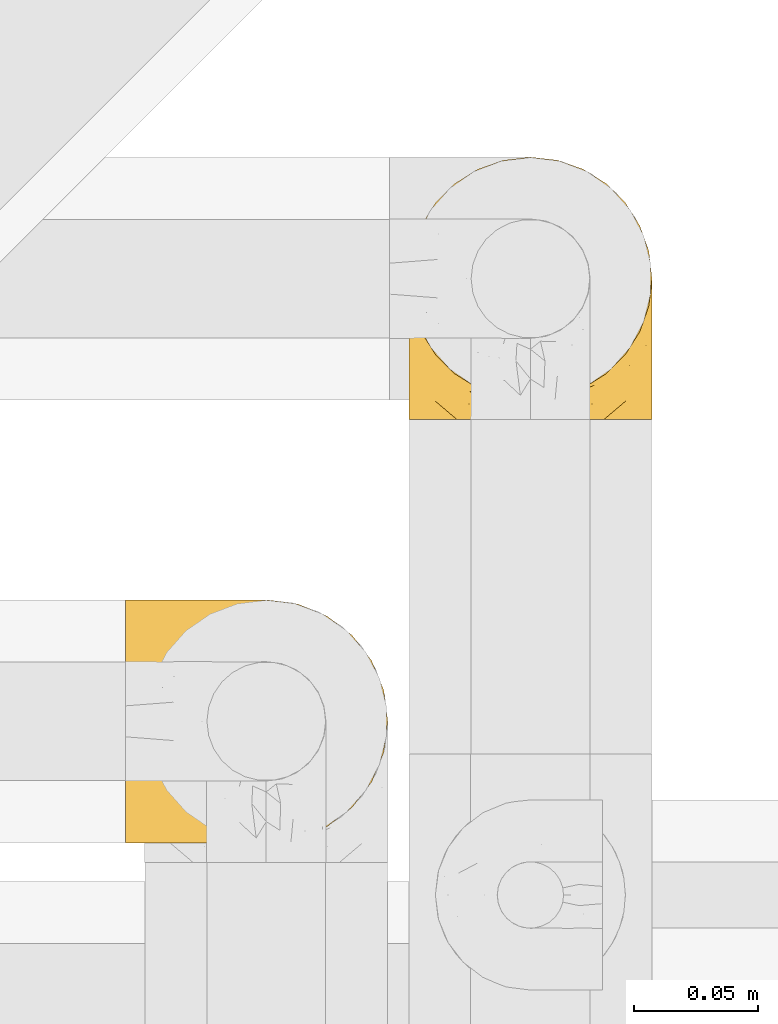
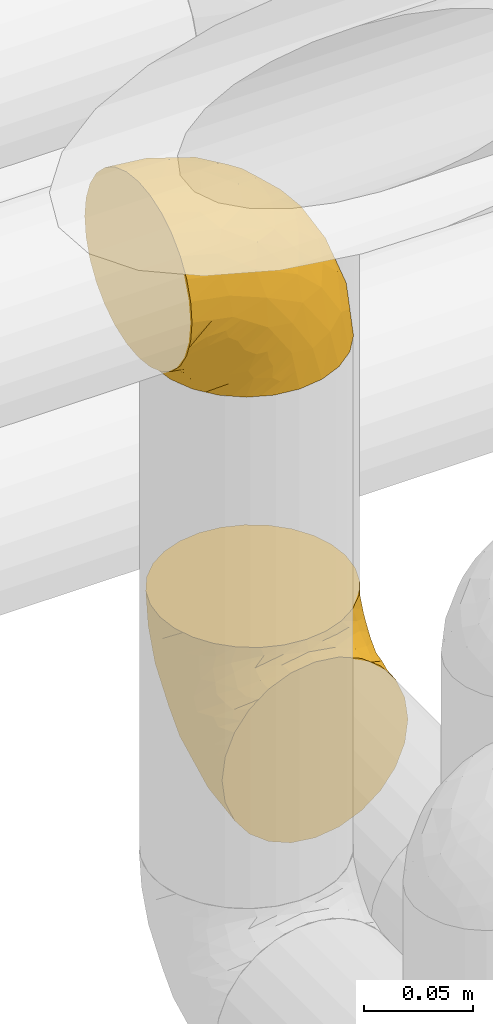
# One storey, part 372 of 827: 2 coverings.
"""IFC2X3 building model written with IfcOpenShell, lengths in millimetres."""

from ifc_helpers import new_model, entity, si_unit, converted_unit, derived_unit, direction, frame, origin, place, context, subcontext, project, spatial, faceted_brep, element, save


model = new_model("IFC2X3")

# Units and contexts
model_context = context("Model", 3, precision=0.01, world=origin(), true_north=direction((6.12303176911189e-17, 1.0)))
body_context = subcontext(model_context, "Body", "Model", "MODEL_VIEW")
ifc_project = project(units=[si_unit("LENGTHUNIT", "METRE", prefix="MILLI"), si_unit("AREAUNIT", "SQUARE_METRE"), si_unit("VOLUMEUNIT", "CUBIC_METRE"), converted_unit("PLANEANGLEUNIT", "DEGREE", entity("IfcRatioMeasure", 0.0174532925199433), si_unit("PLANEANGLEUNIT", "RADIAN"), dimensions=[0, 0, 0, 0, 0, 0, 0]), si_unit("MASSUNIT", "GRAM", prefix="KILO"), derived_unit("MASSDENSITYUNIT", [(si_unit("MASSUNIT", "GRAM", prefix="KILO"), 1), (si_unit("LENGTHUNIT", "METRE"), -3)]), derived_unit("MOMENTOFINERTIAUNIT", [(si_unit("LENGTHUNIT", "METRE"), 4)]), si_unit("TIMEUNIT", "SECOND"), si_unit("FREQUENCYUNIT", "HERTZ"), si_unit("THERMODYNAMICTEMPERATUREUNIT", "DEGREE_CELSIUS"), derived_unit("THERMALTRANSMITTANCEUNIT", [(si_unit("MASSUNIT", "GRAM", prefix="KILO"), 1), (si_unit("THERMODYNAMICTEMPERATUREUNIT", "KELVIN"), -1), (si_unit("TIMEUNIT", "SECOND"), -3)]), derived_unit("VOLUMETRICFLOWRATEUNIT", [(si_unit("LENGTHUNIT", "METRE"), 3), (si_unit("TIMEUNIT", "SECOND"), -1)]), derived_unit("MASSFLOWRATEUNIT", [(si_unit("MASSUNIT", "GRAM", prefix="KILO"), 1), (si_unit("TIMEUNIT", "SECOND"), -1)]), derived_unit("ROTATIONALFREQUENCYUNIT", [(si_unit("TIMEUNIT", "SECOND"), -1)]), si_unit("ELECTRICCURRENTUNIT", "AMPERE"), si_unit("ELECTRICVOLTAGEUNIT", "VOLT"), si_unit("POWERUNIT", "WATT"), si_unit("FORCEUNIT", "NEWTON", prefix="KILO"), si_unit("ILLUMINANCEUNIT", "LUX"), si_unit("LUMINOUSFLUXUNIT", "LUMEN"), si_unit("LUMINOUSINTENSITYUNIT", "CANDELA"), derived_unit("USERDEFINED", [(si_unit("MASSUNIT", "GRAM", prefix="KILO"), -1), (si_unit("LENGTHUNIT", "METRE"), -2), (si_unit("TIMEUNIT", "SECOND"), 3), (si_unit("LUMINOUSFLUXUNIT", "LUMEN"), 1)]), derived_unit("LINEARVELOCITYUNIT", [(si_unit("LENGTHUNIT", "METRE"), 1), (si_unit("TIMEUNIT", "SECOND"), -1)]), si_unit("PRESSUREUNIT", "PASCAL"), derived_unit("USERDEFINED", [(si_unit("LENGTHUNIT", "METRE"), -2), (si_unit("MASSUNIT", "GRAM", prefix="KILO"), 1), (si_unit("TIMEUNIT", "SECOND"), -2)]), derived_unit("LINEARFORCEUNIT", [(si_unit("MASSUNIT", "GRAM", prefix="KILO"), 1), (si_unit("LENGTHUNIT", "METRE"), 1), (si_unit("TIMEUNIT", "SECOND"), -2), (si_unit("LENGTHUNIT", "METRE"), -1)]), derived_unit("PLANARFORCEUNIT", [(si_unit("MASSUNIT", "GRAM", prefix="KILO"), 1), (si_unit("LENGTHUNIT", "METRE"), 1), (si_unit("TIMEUNIT", "SECOND"), -2), (si_unit("LENGTHUNIT", "METRE"), -2)])], contexts=[model_context])

# Site, building, storey
site_placement = place(None, origin())
site = spatial("IfcSite", under=ifc_project, at=site_placement, CompositionType="ELEMENT")
building_placement = place(site_placement, origin())
building = spatial("IfcBuilding", under=site, at=building_placement, CompositionType="ELEMENT")
storey_placement = place(building_placement, frame((0.0, 0.0, 28200.0)))
storey = spatial("IfcBuildingStorey", under=building, at=storey_placement, Name="08", CompositionType="ELEMENT", Elevation=28200.0)

# Coverings
covering_1_placement = place(storey_placement, frame((41310.78, 18885.72, 3341.3)))
element("IfcCovering", 1, at=covering_1_placement, inside=storey, Name=":ADSK_", ObjectType=":ADSK_", PredefinedType="INSULATION", context=body_context, shape_type="Brep", body=[
    faceted_brep([(1.6, 2.83, 69.54), (1.6, 6.47, 79.93), (1.6, 12.32, 89.25), (1.6, 20.11, 97.03), (1.6, 29.43, 102.88), (1.6, 39.81, 106.51), (1.6, 50.75, 107.75), (1.6, 61.69, 106.51), (1.6, 72.08, 102.87), (1.6, 81.4, 97.02), (1.6, 89.18, 89.23), (1.6, 95.03, 79.91), (1.6, 98.66, 69.53), (1.6, 99.9, 58.6), (1.6, 99.25, 52.89), (1.6, 98.66, 47.65), (1.6, 96.84, 42.46), (1.6, 95.02, 37.26), (1.6, 89.17, 27.94), (1.6, 81.38, 20.16), (1.6, 72.06, 14.31), (1.6, 61.68, 10.68), (1.6, 50.75, 9.45), (1.6, 39.8, 10.68), (1.6, 29.41, 14.32), (1.6, 20.09, 20.17), (1.6, 12.31, 27.96), (1.6, 6.46, 37.28), (1.6, 4.64, 42.47), (1.6, 2.83, 47.66), (1.6, 2.24, 52.89), (1.6, 1.92, 55.75), (1.6, 1.6, 58.6), (11.12, 63.47, 1.6), (16.03, 75.32, 1.6), (19.94, 80.41, 1.6), (23.84, 85.5, 1.6), (28.93, 89.41, 1.6), (34.02, 93.31, 1.6), (39.95, 95.77, 1.6), (45.87, 98.22, 1.6), (52.86, 99.14, 1.6), (55.73, 99.52, 1.6), (58.6, 99.9, 1.6), (71.32, 98.22, 1.6), (83.17, 93.31, 1.6), (93.35, 85.5, 1.6), (101.16, 75.32, 1.6), (106.07, 63.47, 1.6), (107.75, 50.75, 1.6), (106.07, 38.03, 1.6), (101.16, 26.17, 1.6), (93.35, 15.99, 1.6), (83.17, 8.18, 1.6), (71.32, 3.27, 1.6), (58.6, 1.6, 1.6), (52.86, 2.35, 1.6), (45.88, 3.27, 1.6), (39.95, 5.73, 1.6), (34.02, 8.18, 1.6), (28.93, 12.09, 1.6), (23.84, 15.99, 1.6), (19.94, 21.08, 1.6), (16.03, 26.17, 1.6), (11.12, 38.02, 1.6), (9.45, 50.75, 1.6), (81.82, 42.19, 69.96), (84.03, 28.42, 59.59), (93.06, 37.78, 51.96), (102.55, 50.75, 34.4), (104.84, 42.85, 23.37), (105.83, 50.75, 13.68), (91.88, 24.75, 41.52), (101.74, 33.81, 26.26), (97.07, 22.57, 20.18), (38.45, 7.18, 72.33), (22.17, 2.73, 65.88), (42.04, 3.09, 57.55), (77.69, 6.92, 23.76), (75.76, 11.58, 46.5), (62.11, 5.17, 46.57), (66.08, 2.71, 21.17), (54.26, 1.6, 23.41), (55.35, 1.6, 17.92), (56.44, 1.6, 12.43), (56.98, 1.6, 9.72), (57.52, 1.6, 7.01), (87.84, 14.18, 26.77), (19.41, 5.88, 76.59), (48.89, 41.06, 95.55), (26.34, 36.25, 102.57), (44.55, 28.62, 92.89), (23.41, 1.6, 54.26), (28.03, 1.6, 51.17), (32.66, 1.6, 48.08), (37.28, 1.6, 44.99), (41.9, 1.6, 41.9), (20.6, 10.85, 85.16), (63.36, 38.35, 85.97), (62.21, 9.6, 59.58), (19.94, 26.24, 99.5), (13.68, 50.75, 105.83), (80.85, 19.31, 53.59), (66.53, 16.41, 67.0), (71.06, 24.56, 71.56), (63.99, 50.75, 87.47), (75.73, 50.75, 75.73), (26.77, 18.48, 92.24), (4.31, 1.6, 58.06), (7.02, 1.6, 57.52), (12.44, 1.6, 56.44), (17.92, 1.6, 55.35), (43.43, 14.36, 81.33), (56.23, 20.64, 80.35), (54.97, 2.32, 39.44), (34.4, 50.75, 102.55), (44.99, 1.6, 37.28), (48.08, 1.6, 32.65), (51.17, 1.6, 28.03), (87.47, 50.75, 63.99), (74.55, 33.89, 74.55), (60.86, 29.24, 83.62), (49.19, 50.75, 95.01), (95.01, 50.75, 49.19), (10.27, 2.8, 46.96), (48.79, 2.48, 8.77), (45.16, 2.7, 18.28), (44.99, 3.2, 11.68), (6.17, 32.98, 11.79), (7.65, 24.67, 15.69), (21.59, 2.95, 42.49), (19.96, 2.19, 47.41), (21.0, 17.92, 7.94), (27.2, 12.02, 9.27), (14.83, 25.73, 7.98), (19.7, 16.63, 13.4), (10.93, 25.6, 13.04), (9.63, 36.72, 7.36), (19.97, 10.66, 23.46), (21.13, 6.87, 30.46), (14.14, 11.12, 26.54), (30.2, 10.31, 6.76), (36.66, 5.94, 12.75), (8.12, 12.84, 26.46), (9.93, 17.38, 20.77), (24.62, 9.74, 20.68), (11.87, 4.63, 40.26), (7.15, 50.75, 7.15), (5.32, 42.52, 9.28), (26.68, 3.12, 38.78), (13.92, 17.58, 18.27), (30.67, 3.97, 31.78), (42.89, 2.73, 22.96), (34.04, 6.23, 17.55), (36.6, 3.45, 27.63), (26.41, 10.84, 15.23), (10.07, 7.98, 33.25), (15.83, 7.33, 32.43), (42.0, 2.39, 27.9), (14.83, 75.76, 7.97), (26.4, 90.65, 15.22), (21.01, 83.57, 7.93), (19.71, 84.85, 13.38), (5.73, 71.05, 13.12), (21.6, 98.54, 42.49), (19.96, 99.3, 47.4), (28.03, 99.9, 51.17), (11.87, 96.86, 40.24), (9.93, 84.1, 20.76), (58.06, 99.9, 4.31), (56.44, 99.9, 12.43), (57.52, 99.9, 7.01), (8.13, 88.63, 26.44), (14.15, 90.36, 26.52), (44.99, 98.29, 11.68), (36.65, 95.55, 12.75), (30.2, 91.18, 6.76), (10.06, 93.49, 33.21), (15.83, 94.15, 32.41), (48.79, 99.01, 8.77), (42.89, 98.76, 22.96), (45.38, 98.85, 18.48), (12.43, 99.9, 56.44), (10.28, 98.69, 46.95), (9.64, 64.78, 7.36), (55.35, 99.9, 17.92), (54.26, 99.9, 23.41), (6.05, 62.91, 9.85), (7.01, 99.9, 57.52), (9.72, 99.9, 56.98), (32.65, 99.9, 48.08), (26.68, 98.37, 38.78), (13.92, 83.9, 18.25), (37.28, 99.9, 44.99), (30.66, 97.51, 31.74), (21.14, 94.62, 30.45), (36.59, 98.04, 27.63), (24.6, 91.73, 20.65), (17.92, 99.9, 55.35), (23.41, 99.9, 54.26), (10.93, 75.87, 13.03), (19.97, 90.83, 23.44), (41.99, 99.1, 27.9), (48.08, 99.9, 32.65), (34.04, 95.26, 17.55), (27.21, 89.47, 9.27), (51.17, 99.9, 28.03), (44.99, 99.9, 37.28), (41.9, 99.9, 41.9), (55.26, 99.09, 39.74), (104.84, 58.64, 23.37), (87.84, 87.31, 26.77), (75.91, 89.93, 46.18), (80.84, 82.22, 53.54), (91.87, 76.74, 41.53), (83.98, 73.12, 59.61), (19.16, 95.54, 76.79), (22.37, 98.7, 66.11), (66.08, 98.79, 21.17), (93.05, 63.72, 51.96), (101.74, 67.69, 26.26), (97.07, 78.92, 20.18), (77.69, 94.57, 23.76), (44.55, 72.88, 92.88), (26.34, 65.25, 102.57), (48.9, 60.44, 95.54), (70.99, 76.94, 71.63), (74.55, 67.61, 74.55), (37.8, 94.38, 72.51), (81.82, 59.31, 69.96), (26.77, 83.03, 92.23), (20.6, 90.66, 85.15), (56.15, 80.8, 80.45), (60.85, 72.22, 83.65), (42.06, 98.39, 57.57), (57.03, 92.31, 63.68), (63.4, 63.11, 85.95), (19.95, 75.27, 99.49), (43.59, 87.15, 81.23), (62.61, 96.03, 47.07), (66.52, 85.1, 66.99)], [[[0, 1, 2, 3, 4, 5, 6, 7, 8, 9, 10, 11, 12, 13, 14, 15, 16, 17, 18, 19, 20, 21, 22, 23, 24, 25, 26, 27, 28, 29, 30, 31, 32]], [[33, 34, 35, 36, 37, 38, 39, 40, 41, 42, 43, 44, 45, 46, 47, 48, 49, 50, 51, 52, 53, 54, 55, 56, 57, 58, 59, 60, 61, 62, 63, 64, 65]], [[66, 67, 68]], [[69, 70, 71]], [[68, 72, 73]], [[73, 72, 74]], [[75, 76, 77]], [[78, 79, 80]], [[51, 50, 73]], [[81, 82, 83, 84, 85, 86, 55]], [[52, 87, 53]], [[74, 52, 51]], [[1, 0, 88]], [[89, 90, 91]], [[77, 92, 93, 94, 95, 96]], [[55, 54, 81]], [[78, 53, 87]], [[4, 90, 5]], [[88, 76, 75]], [[97, 2, 1]], [[89, 91, 98]], [[99, 80, 79]], [[90, 4, 100]], [[74, 87, 52]], [[100, 4, 3]], [[90, 101, 5]], [[79, 102, 103]], [[102, 67, 104]], [[105, 98, 106]], [[107, 3, 2]], [[76, 32, 108, 109, 110, 111, 92]], [[107, 112, 113]], [[114, 77, 96]], [[89, 115, 90]], [[114, 96, 116, 117, 118, 82]], [[75, 97, 88]], [[119, 66, 68]], [[50, 71, 70]], [[100, 91, 90]], [[99, 77, 80]], [[102, 104, 103]], [[97, 107, 2]], [[80, 81, 78]], [[107, 97, 112]], [[68, 73, 70]], [[66, 98, 120]], [[78, 81, 54]], [[114, 81, 80]], [[53, 78, 54]], [[78, 87, 79]], [[102, 87, 72]], [[79, 103, 99]], [[3, 107, 100]], [[91, 100, 107]], [[88, 97, 1]], [[112, 97, 75]], [[99, 112, 75]], [[103, 104, 113]], [[91, 121, 98]], [[89, 105, 122, 115]], [[101, 90, 115]], [[101, 6, 5]], [[88, 0, 76]], [[32, 76, 0]], [[92, 77, 76]], [[73, 74, 51]], [[87, 74, 72]], [[81, 114, 82]], [[77, 114, 80]], [[87, 102, 79]], [[67, 102, 72]], [[68, 67, 72]], [[67, 120, 104]], [[120, 121, 104]], [[104, 121, 113]], [[121, 120, 98]], [[91, 107, 113]], [[91, 113, 121]], [[103, 113, 112]], [[66, 119, 106]], [[105, 89, 98]], [[68, 69, 123, 119]], [[98, 66, 106]], [[66, 120, 67]], [[50, 49, 71]], [[50, 70, 73]], [[112, 99, 103]], [[77, 99, 75]], [[69, 68, 70]], [[28, 124, 110]], [[84, 83, 125]], [[126, 82, 118]], [[59, 58, 127]], [[24, 128, 129]], [[130, 93, 131]], [[132, 62, 133]], [[134, 135, 136]], [[137, 65, 64]], [[64, 134, 137]], [[138, 139, 140]], [[111, 110, 124, 92]], [[134, 136, 137]], [[134, 64, 63]], [[141, 60, 142]], [[125, 58, 57]], [[143, 144, 140]], [[143, 25, 144]], [[127, 83, 82]], [[27, 124, 28]], [[108, 32, 31, 30, 29, 110, 109]], [[29, 28, 110]], [[135, 145, 138]], [[27, 146, 124]], [[57, 56, 55, 86, 85, 84]], [[147, 148, 22]], [[23, 22, 148]], [[24, 144, 25]], [[95, 94, 149]], [[23, 128, 24]], [[150, 138, 144]], [[124, 146, 131]], [[127, 58, 125]], [[151, 149, 139]], [[127, 126, 142]], [[142, 59, 127]], [[152, 142, 126]], [[153, 154, 155]], [[153, 133, 141]], [[146, 27, 26]], [[143, 156, 26]], [[157, 149, 130]], [[61, 133, 62]], [[134, 132, 135]], [[148, 128, 23]], [[65, 137, 147]], [[147, 137, 148]], [[128, 137, 136]], [[137, 128, 148]], [[128, 136, 129]], [[150, 129, 136]], [[24, 129, 144]], [[158, 152, 117]], [[152, 118, 117]], [[153, 142, 152]], [[158, 116, 154]], [[145, 151, 138]], [[153, 152, 158]], [[133, 153, 155]], [[133, 155, 132]], [[153, 141, 142]], [[135, 132, 155]], [[134, 63, 132]], [[145, 135, 155]], [[135, 138, 150]], [[155, 154, 145]], [[151, 154, 96]], [[154, 151, 145]], [[149, 94, 130]], [[82, 126, 127]], [[118, 152, 126]], [[151, 96, 95]], [[139, 149, 157]], [[151, 95, 149]], [[93, 92, 131]], [[130, 146, 156]], [[130, 94, 93]], [[84, 125, 57]], [[127, 125, 83]], [[140, 139, 157]], [[151, 139, 138]], [[140, 157, 143]], [[138, 140, 144]], [[156, 143, 157]], [[26, 25, 143]], [[130, 156, 157]], [[146, 26, 156]], [[132, 63, 62]], [[124, 131, 92]], [[130, 131, 146]], [[129, 150, 144]], [[135, 150, 136]], [[60, 141, 61]], [[60, 59, 142]], [[133, 61, 141]], [[116, 96, 154]], [[153, 158, 154]], [[158, 117, 116]], [[34, 33, 159]], [[160, 161, 162]], [[21, 20, 163]], [[164, 165, 166]], [[18, 17, 167]], [[168, 20, 19]], [[169, 43, 42, 41, 40, 170, 171]], [[172, 173, 168]], [[174, 38, 175]], [[37, 36, 176]], [[177, 164, 178]], [[40, 179, 170]], [[180, 181, 175]], [[16, 182, 183]], [[65, 147, 184]], [[185, 174, 186]], [[22, 21, 187]], [[174, 39, 38]], [[14, 13, 188, 189, 182, 15]], [[179, 40, 39]], [[190, 191, 164]], [[192, 163, 168]], [[33, 184, 159]], [[178, 173, 172]], [[193, 194, 191]], [[17, 183, 167]], [[173, 178, 195]], [[196, 197, 194]], [[198, 199, 183, 182]], [[182, 16, 15]], [[17, 16, 183]], [[200, 159, 184]], [[192, 168, 201]], [[187, 163, 200]], [[202, 203, 180]], [[185, 179, 174]], [[160, 204, 205]], [[206, 181, 180]], [[206, 180, 203]], [[199, 165, 183]], [[165, 164, 167]], [[172, 177, 178]], [[200, 192, 162]], [[205, 161, 160]], [[65, 184, 33]], [[163, 187, 21]], [[175, 204, 180]], [[174, 181, 186]], [[204, 196, 202]], [[197, 160, 162]], [[196, 207, 202]], [[37, 176, 175]], [[196, 204, 160]], [[176, 204, 175]], [[205, 35, 161]], [[34, 159, 161]], [[162, 161, 159]], [[200, 162, 159]], [[197, 162, 201]], [[194, 197, 201]], [[196, 160, 197]], [[191, 195, 178]], [[208, 196, 194]], [[186, 181, 206]], [[175, 181, 174]], [[191, 190, 193]], [[193, 208, 194]], [[195, 194, 201]], [[178, 164, 191]], [[168, 163, 20]], [[166, 165, 199]], [[166, 190, 164]], [[187, 200, 184]], [[184, 147, 187]], [[22, 187, 147]], [[174, 179, 39]], [[170, 179, 185]], [[194, 195, 191]], [[173, 201, 168]], [[201, 173, 195]], [[172, 168, 19]], [[19, 18, 172]], [[177, 172, 18]], [[18, 167, 177]], [[164, 177, 167]], [[35, 205, 36]], [[35, 34, 161]], [[183, 165, 167]], [[162, 192, 201]], [[163, 192, 200]], [[175, 38, 37]], [[36, 205, 176]], [[204, 176, 205]], [[204, 202, 180]], [[207, 196, 208]], [[207, 203, 202]], [[209, 186, 206, 203, 207, 208]], [[48, 210, 71]], [[211, 212, 213]], [[214, 213, 215]], [[216, 217, 12]], [[218, 43, 169, 171, 170, 185, 186]], [[219, 220, 214]], [[47, 46, 221]], [[210, 48, 220]], [[211, 222, 212]], [[222, 45, 44]], [[221, 220, 47]], [[47, 220, 48]], [[221, 211, 214]], [[223, 224, 225]], [[211, 46, 45]], [[226, 227, 215]], [[43, 218, 44]], [[217, 216, 228]], [[219, 215, 229]], [[13, 12, 217]], [[224, 8, 7]], [[9, 230, 10]], [[10, 231, 11]], [[232, 223, 233]], [[234, 208, 193, 190, 166, 199]], [[235, 234, 228]], [[222, 44, 218]], [[106, 229, 236]], [[224, 237, 8]], [[231, 238, 228]], [[8, 237, 9]], [[115, 224, 101]], [[239, 234, 235]], [[231, 10, 230]], [[223, 230, 237]], [[224, 7, 101]], [[223, 236, 233]], [[225, 115, 122, 105]], [[216, 11, 231]], [[209, 234, 239]], [[210, 219, 69]], [[219, 214, 215]], [[229, 119, 219]], [[209, 218, 186]], [[239, 212, 222]], [[239, 222, 218]], [[45, 222, 211]], [[235, 212, 239]], [[213, 212, 240]], [[223, 237, 224]], [[230, 9, 237]], [[238, 231, 230]], [[216, 231, 228]], [[232, 230, 223]], [[235, 238, 240]], [[115, 225, 224]], [[233, 236, 227]], [[7, 6, 101]], [[234, 209, 208]], [[218, 209, 239]], [[217, 228, 234]], [[12, 11, 216]], [[234, 199, 217]], [[217, 199, 198, 182, 189, 188, 13]], [[211, 221, 46]], [[220, 221, 214]], [[71, 210, 69]], [[71, 49, 48]], [[219, 210, 220]], [[226, 215, 213]], [[211, 213, 214]], [[226, 213, 240]], [[215, 227, 229]], [[232, 240, 238]], [[233, 227, 226]], [[232, 233, 226]], [[236, 223, 225]], [[240, 232, 226]], [[232, 238, 230]], [[225, 105, 236]], [[236, 105, 106]], [[236, 229, 227]], [[123, 69, 219, 119]], [[106, 119, 229]], [[238, 235, 228]], [[212, 235, 240]]]),
])
covering_2_placement = place(storey_placement, frame((41425.47, 19056.89, 2949.25)))
element("IfcCovering", 2, at=covering_2_placement, inside=storey, Name=":ADSK_", ObjectType=":ADSK_", PredefinedType="INSULATION", context=body_context, shape_type="Brep", body=[
    faceted_brep([(99.9, 58.6, 107.75), (98.66, 69.54, 107.75), (95.02, 79.93, 107.75), (89.17, 89.25, 107.75), (81.38, 97.03, 107.75), (72.06, 102.88, 107.75), (61.68, 106.51, 107.75), (50.75, 107.75, 107.75), (39.8, 106.51, 107.75), (29.41, 102.87, 107.75), (20.09, 97.02, 107.75), (12.31, 89.23, 107.75), (6.46, 79.91, 107.75), (2.83, 69.53, 107.75), (1.6, 58.6, 107.75), (2.24, 52.89, 107.75), (2.83, 47.65, 107.75), (4.65, 42.46, 107.75), (6.47, 37.26, 107.75), (12.32, 27.94, 107.75), (20.11, 20.16, 107.75), (29.43, 14.31, 107.75), (39.81, 10.68, 107.75), (50.75, 9.45, 107.75), (61.69, 10.68, 107.75), (72.08, 14.32, 107.75), (81.4, 20.17, 107.75), (89.18, 27.96, 107.75), (95.03, 37.28, 107.75), (96.85, 42.47, 107.75), (98.66, 47.66, 107.75), (99.25, 52.89, 107.75), (99.57, 55.75, 107.75), (38.02, 1.6, 98.22), (26.17, 1.6, 93.31), (21.08, 1.6, 89.4), (15.99, 1.6, 85.5), (12.09, 1.6, 80.41), (8.18, 1.6, 75.32), (5.73, 1.6, 69.39), (3.27, 1.6, 63.47), (2.35, 1.6, 56.48), (1.97, 1.6, 53.61), (1.6, 1.6, 50.75), (3.27, 1.6, 38.02), (8.18, 1.6, 26.17), (15.99, 1.6, 15.99), (26.17, 1.6, 8.18), (38.02, 1.6, 3.27), (50.75, 1.6, 1.6), (63.47, 1.6, 3.27), (75.32, 1.6, 8.18), (85.5, 1.6, 15.99), (93.31, 1.6, 26.17), (98.22, 1.6, 38.02), (99.9, 1.6, 50.75), (99.14, 1.6, 56.48), (98.22, 1.6, 63.47), (95.77, 1.6, 69.39), (93.31, 1.6, 75.32), (89.4, 1.6, 80.41), (85.5, 1.6, 85.5), (80.41, 1.6, 89.4), (75.32, 1.6, 93.31), (63.47, 1.6, 98.22), (50.75, 1.6, 99.9), (59.31, 69.96, 27.53), (73.08, 59.59, 25.32), (63.72, 51.96, 16.29), (50.75, 34.4, 6.79), (58.64, 23.37, 4.51), (50.75, 13.68, 3.51), (76.74, 41.52, 17.47), (67.68, 26.26, 7.6), (78.92, 20.18, 12.27), (94.31, 72.33, 70.89), (98.76, 65.88, 87.17), (98.4, 57.55, 67.3), (94.57, 23.76, 31.65), (89.91, 46.5, 33.58), (96.32, 46.57, 47.23), (98.79, 21.17, 43.26), (99.9, 23.41, 55.08), (99.9, 17.92, 53.99), (99.9, 12.43, 52.9), (99.9, 9.72, 52.36), (99.9, 7.01, 51.82), (87.31, 26.77, 21.5), (95.61, 76.59, 89.94), (60.43, 95.55, 60.45), (65.24, 102.57, 83.0), (72.87, 92.89, 64.79), (99.9, 54.26, 85.93), (99.9, 51.17, 81.31), (99.9, 48.08, 76.69), (99.9, 44.99, 72.06), (99.9, 41.9, 67.44), (90.65, 85.16, 88.74), (63.14, 85.97, 45.98), (91.89, 59.58, 47.13), (75.25, 99.5, 89.4), (50.75, 105.83, 95.66), (82.18, 53.59, 28.5), (85.08, 67.0, 42.81), (76.93, 71.56, 38.28), (50.75, 87.47, 45.35), (50.75, 75.73, 33.61), (83.02, 92.24, 82.57), (99.9, 58.06, 105.04), (99.9, 57.52, 102.33), (99.9, 56.44, 96.91), (99.9, 55.35, 91.42), (87.13, 81.33, 65.92), (80.85, 80.35, 53.11), (99.17, 39.44, 54.37), (50.75, 102.55, 74.94), (99.9, 37.28, 64.35), (99.9, 32.65, 61.26), (99.9, 28.03, 58.17), (50.75, 63.99, 21.87), (67.61, 74.55, 34.79), (72.25, 83.62, 48.48), (50.75, 95.01, 60.15), (50.75, 49.19, 14.33), (98.69, 46.96, 99.07), (99.01, 8.77, 60.55), (98.79, 18.28, 64.18), (98.29, 11.68, 64.36), (68.51, 11.79, 103.17), (76.82, 15.69, 101.69), (98.54, 42.49, 87.75), (99.3, 47.41, 89.38), (83.57, 7.94, 88.34), (89.47, 9.27, 82.14), (75.76, 7.98, 94.51), (84.86, 13.4, 89.64), (75.89, 13.04, 98.41), (64.77, 7.36, 99.71), (90.83, 23.46, 89.37), (94.62, 30.46, 88.21), (90.37, 26.54, 95.2), (91.18, 6.76, 79.14), (88.65, 26.46, 101.22), (84.11, 20.77, 99.41), (91.75, 20.68, 84.72), (96.86, 40.26, 97.47), (50.75, 7.15, 102.19), (58.97, 9.28, 104.02), (98.37, 38.78, 82.66), (83.91, 18.27, 95.42), (97.52, 31.78, 78.67), (95.55, 12.75, 72.69), (98.76, 22.96, 66.46), (95.26, 17.55, 75.3), (98.04, 27.63, 72.74), (90.65, 15.23, 82.93), (93.51, 33.25, 99.27), (94.16, 32.43, 93.51), (99.1, 27.9, 67.35), (25.73, 7.97, 94.51), (10.84, 15.22, 82.94), (17.92, 7.93, 88.33), (16.64, 13.38, 89.64), (30.44, 13.12, 103.62), (2.95, 42.49, 87.74), (2.19, 47.4, 89.38), (1.6, 51.17, 81.31), (4.63, 40.24, 97.47), (17.39, 20.76, 99.41), (1.6, 12.43, 52.9), (1.6, 7.01, 51.82), (1.6, 4.31, 51.28), (12.86, 26.44, 101.21), (11.13, 26.52, 95.19), (3.2, 11.68, 64.36), (5.94, 12.75, 72.69), (12.02, 9.27, 82.13), (6.23, 17.55, 75.3), (10.31, 6.76, 79.14), (8.0, 33.21, 99.28), (7.34, 32.41, 93.51), (2.48, 8.77, 60.55), (2.73, 22.96, 66.46), (2.64, 18.48, 63.96), (1.6, 56.44, 96.91), (2.8, 46.95, 99.06), (36.71, 7.36, 99.7), (1.6, 17.92, 53.99), (1.6, 23.41, 55.08), (38.59, 9.85, 103.3), (1.6, 57.52, 102.33), (1.6, 56.98, 99.62), (1.6, 48.08, 76.69), (3.12, 38.78, 82.66), (17.59, 18.25, 95.42), (1.6, 44.99, 72.06), (3.98, 31.74, 78.68), (6.87, 30.45, 88.2), (3.45, 27.63, 72.75), (9.76, 20.65, 84.74), (1.6, 55.35, 91.42), (1.6, 54.26, 85.93), (25.62, 13.03, 98.41), (10.67, 23.44, 89.37), (2.39, 27.9, 67.35), (1.6, 32.65, 61.26), (1.6, 28.03, 58.17), (1.6, 37.28, 64.35), (1.6, 41.9, 67.44), (2.4, 39.74, 54.08), (42.85, 23.37, 4.51), (14.18, 26.77, 21.5), (11.56, 46.18, 33.43), (19.27, 53.54, 28.5), (24.75, 41.53, 17.47), (28.37, 59.61, 25.36), (5.95, 76.79, 90.18), (2.79, 66.11, 86.97), (2.71, 21.17, 43.26), (37.78, 51.96, 16.29), (33.81, 26.26, 7.6), (22.57, 20.18, 12.27), (6.92, 23.76, 31.65), (28.61, 92.88, 64.79), (36.24, 102.57, 83.0), (41.05, 95.54, 60.44), (24.55, 71.63, 38.35), (33.88, 74.55, 34.8), (7.11, 72.51, 71.54), (42.18, 69.96, 27.53), (18.46, 92.23, 82.57), (10.84, 85.15, 88.74), (20.69, 80.45, 53.19), (29.27, 83.65, 48.49), (3.1, 57.57, 67.28), (9.18, 63.68, 52.32), (38.38, 85.95, 45.94), (26.23, 99.49, 89.4), (14.34, 81.23, 65.75), (5.46, 47.07, 46.73), (16.39, 66.99, 42.82)], [[[0, 1, 2, 3, 4, 5, 6, 7, 8, 9, 10, 11, 12, 13, 14, 15, 16, 17, 18, 19, 20, 21, 22, 23, 24, 25, 26, 27, 28, 29, 30, 31, 32]], [[33, 34, 35, 36, 37, 38, 39, 40, 41, 42, 43, 44, 45, 46, 47, 48, 49, 50, 51, 52, 53, 54, 55, 56, 57, 58, 59, 60, 61, 62, 63, 64, 65]], [[66, 67, 68]], [[69, 70, 71]], [[68, 72, 73]], [[73, 72, 74]], [[75, 76, 77]], [[78, 79, 80]], [[51, 50, 73]], [[81, 82, 83, 84, 85, 86, 55]], [[52, 87, 53]], [[74, 52, 51]], [[2, 1, 88]], [[89, 90, 91]], [[77, 92, 93, 94, 95, 96]], [[55, 54, 81]], [[78, 53, 87]], [[5, 90, 6]], [[88, 76, 75]], [[97, 3, 2]], [[89, 91, 98]], [[99, 80, 79]], [[90, 5, 100]], [[74, 87, 52]], [[100, 5, 4]], [[90, 101, 6]], [[79, 102, 103]], [[102, 67, 104]], [[105, 98, 106]], [[107, 4, 3]], [[76, 0, 108, 109, 110, 111, 92]], [[107, 112, 113]], [[114, 77, 96]], [[89, 115, 90]], [[114, 96, 116, 117, 118, 82]], [[75, 97, 88]], [[119, 66, 68]], [[50, 71, 70]], [[100, 91, 90]], [[99, 77, 80]], [[102, 104, 103]], [[97, 107, 3]], [[80, 81, 78]], [[107, 97, 112]], [[68, 73, 70]], [[66, 98, 120]], [[78, 81, 54]], [[114, 81, 80]], [[53, 78, 54]], [[78, 87, 79]], [[102, 87, 72]], [[79, 103, 99]], [[4, 107, 100]], [[91, 100, 107]], [[88, 97, 2]], [[112, 97, 75]], [[99, 112, 75]], [[103, 104, 113]], [[91, 121, 98]], [[89, 105, 122, 115]], [[101, 90, 115]], [[101, 7, 6]], [[88, 1, 76]], [[0, 76, 1]], [[92, 77, 76]], [[73, 74, 51]], [[87, 74, 72]], [[81, 114, 82]], [[77, 114, 80]], [[87, 102, 79]], [[67, 102, 72]], [[68, 67, 72]], [[67, 120, 104]], [[120, 121, 104]], [[104, 121, 113]], [[121, 120, 98]], [[91, 107, 113]], [[91, 113, 121]], [[103, 113, 112]], [[106, 98, 66]], [[105, 89, 98]], [[106, 66, 119]], [[67, 66, 120]], [[68, 69, 123, 119]], [[50, 49, 71]], [[50, 70, 73]], [[112, 99, 103]], [[77, 99, 75]], [[69, 68, 70]], [[29, 124, 110]], [[84, 83, 125]], [[126, 82, 118]], [[59, 58, 127]], [[25, 128, 129]], [[130, 93, 131]], [[132, 62, 133]], [[134, 135, 136]], [[137, 65, 64]], [[64, 134, 137]], [[138, 139, 140]], [[111, 110, 124, 92]], [[134, 136, 137]], [[134, 64, 63]], [[141, 61, 60]], [[125, 58, 57]], [[142, 143, 140]], [[142, 26, 143]], [[127, 83, 82]], [[28, 124, 29]], [[108, 0, 32, 31, 30, 110, 109]], [[30, 29, 110]], [[135, 144, 138]], [[28, 145, 124]], [[57, 56, 55, 86, 85, 84]], [[146, 147, 23]], [[24, 23, 147]], [[25, 143, 26]], [[95, 94, 148]], [[24, 128, 25]], [[149, 138, 143]], [[124, 145, 131]], [[127, 58, 125]], [[150, 148, 139]], [[127, 126, 151]], [[151, 59, 127]], [[152, 151, 126]], [[153, 154, 155]], [[153, 133, 141]], [[145, 28, 27]], [[142, 156, 27]], [[157, 148, 130]], [[61, 133, 62]], [[134, 132, 135]], [[147, 128, 24]], [[65, 137, 146]], [[146, 137, 147]], [[128, 137, 136]], [[137, 128, 147]], [[128, 136, 129]], [[149, 129, 136]], [[25, 129, 143]], [[158, 152, 117]], [[152, 118, 117]], [[153, 151, 152]], [[158, 116, 154]], [[144, 150, 138]], [[153, 152, 158]], [[133, 153, 155]], [[133, 155, 132]], [[60, 151, 141]], [[135, 132, 155]], [[134, 63, 132]], [[144, 135, 155]], [[135, 138, 149]], [[155, 154, 144]], [[150, 154, 96]], [[154, 150, 144]], [[148, 94, 130]], [[82, 126, 127]], [[118, 152, 126]], [[150, 96, 95]], [[139, 148, 157]], [[150, 95, 148]], [[93, 92, 131]], [[130, 145, 156]], [[130, 94, 93]], [[84, 125, 57]], [[127, 125, 83]], [[140, 139, 157]], [[150, 139, 138]], [[140, 157, 142]], [[138, 140, 143]], [[156, 142, 157]], [[27, 26, 142]], [[130, 156, 157]], [[145, 27, 156]], [[132, 63, 62]], [[124, 131, 92]], [[130, 131, 145]], [[129, 149, 143]], [[135, 149, 136]], [[141, 133, 61]], [[60, 59, 151]], [[141, 151, 153]], [[116, 96, 154]], [[153, 158, 154]], [[158, 117, 116]], [[34, 33, 159]], [[160, 161, 162]], [[22, 21, 163]], [[164, 165, 166]], [[19, 18, 167]], [[168, 21, 20]], [[42, 41, 40, 169, 170, 171, 43]], [[172, 173, 168]], [[174, 38, 175]], [[176, 177, 178]], [[179, 164, 180]], [[40, 181, 169]], [[182, 183, 175]], [[17, 184, 185]], [[65, 146, 186]], [[187, 174, 188]], [[23, 22, 189]], [[174, 39, 38]], [[15, 14, 190, 191, 184, 16]], [[181, 40, 39]], [[192, 193, 164]], [[194, 163, 168]], [[33, 186, 159]], [[180, 173, 172]], [[195, 196, 193]], [[18, 185, 167]], [[173, 180, 197]], [[198, 199, 196]], [[200, 201, 185, 184]], [[184, 17, 16]], [[18, 17, 185]], [[202, 159, 186]], [[194, 168, 203]], [[189, 163, 202]], [[204, 205, 182]], [[187, 181, 174]], [[160, 177, 176]], [[206, 183, 182]], [[206, 182, 205]], [[201, 165, 185]], [[165, 164, 167]], [[172, 179, 180]], [[202, 194, 162]], [[176, 161, 160]], [[65, 186, 33]], [[163, 189, 22]], [[175, 177, 182]], [[174, 183, 188]], [[177, 198, 204]], [[199, 160, 162]], [[198, 207, 204]], [[175, 38, 37]], [[198, 177, 160]], [[178, 177, 175]], [[176, 35, 161]], [[34, 159, 161]], [[162, 161, 159]], [[202, 162, 159]], [[199, 162, 203]], [[196, 199, 203]], [[198, 160, 199]], [[193, 197, 180]], [[208, 198, 196]], [[188, 183, 206]], [[175, 183, 174]], [[193, 192, 195]], [[195, 208, 196]], [[197, 196, 203]], [[180, 164, 193]], [[168, 163, 21]], [[166, 165, 201]], [[166, 192, 164]], [[189, 202, 186]], [[186, 146, 189]], [[23, 189, 146]], [[174, 181, 39]], [[169, 181, 187]], [[196, 197, 193]], [[173, 203, 168]], [[203, 173, 197]], [[172, 168, 20]], [[20, 19, 172]], [[179, 172, 19]], [[19, 167, 179]], [[164, 179, 167]], [[35, 176, 36]], [[35, 34, 161]], [[185, 165, 167]], [[162, 194, 203]], [[163, 194, 202]], [[176, 178, 36]], [[37, 36, 178]], [[175, 37, 178]], [[177, 204, 182]], [[207, 198, 208]], [[207, 205, 204]], [[209, 188, 206, 205, 207, 208]], [[48, 210, 71]], [[211, 212, 213]], [[214, 213, 215]], [[216, 217, 13]], [[218, 43, 171, 170, 169, 187, 188]], [[219, 220, 214]], [[47, 46, 221]], [[210, 48, 220]], [[211, 222, 212]], [[222, 45, 44]], [[221, 220, 47]], [[47, 220, 48]], [[221, 211, 214]], [[223, 224, 225]], [[211, 46, 45]], [[226, 227, 215]], [[43, 218, 44]], [[217, 216, 228]], [[219, 215, 229]], [[14, 13, 217]], [[224, 9, 8]], [[10, 230, 11]], [[11, 231, 12]], [[232, 223, 233]], [[234, 208, 195, 192, 166, 201]], [[235, 234, 228]], [[222, 44, 218]], [[106, 229, 236]], [[224, 237, 9]], [[231, 238, 228]], [[9, 237, 10]], [[115, 224, 101]], [[239, 234, 235]], [[231, 11, 230]], [[223, 230, 237]], [[224, 8, 101]], [[223, 236, 233]], [[225, 115, 122, 105]], [[216, 12, 231]], [[209, 234, 239]], [[210, 219, 69]], [[219, 214, 215]], [[229, 119, 219]], [[209, 218, 188]], [[239, 212, 222]], [[239, 222, 218]], [[45, 222, 211]], [[235, 212, 239]], [[213, 212, 240]], [[223, 237, 224]], [[230, 10, 237]], [[238, 231, 230]], [[216, 231, 228]], [[232, 230, 223]], [[235, 238, 240]], [[115, 225, 224]], [[233, 236, 227]], [[8, 7, 101]], [[234, 209, 208]], [[218, 209, 239]], [[217, 228, 234]], [[13, 12, 216]], [[234, 201, 217]], [[217, 201, 200, 184, 191, 190, 14]], [[211, 221, 46]], [[220, 221, 214]], [[71, 210, 69]], [[71, 49, 48]], [[219, 210, 220]], [[226, 215, 213]], [[211, 213, 214]], [[226, 213, 240]], [[215, 227, 229]], [[232, 240, 238]], [[233, 227, 226]], [[232, 233, 226]], [[236, 223, 225]], [[240, 232, 226]], [[232, 238, 230]], [[225, 105, 236]], [[236, 105, 106]], [[236, 229, 227]], [[123, 69, 219, 119]], [[106, 119, 229]], [[238, 235, 228]], [[212, 235, 240]]]),
])

save(model, "model.ifc")
